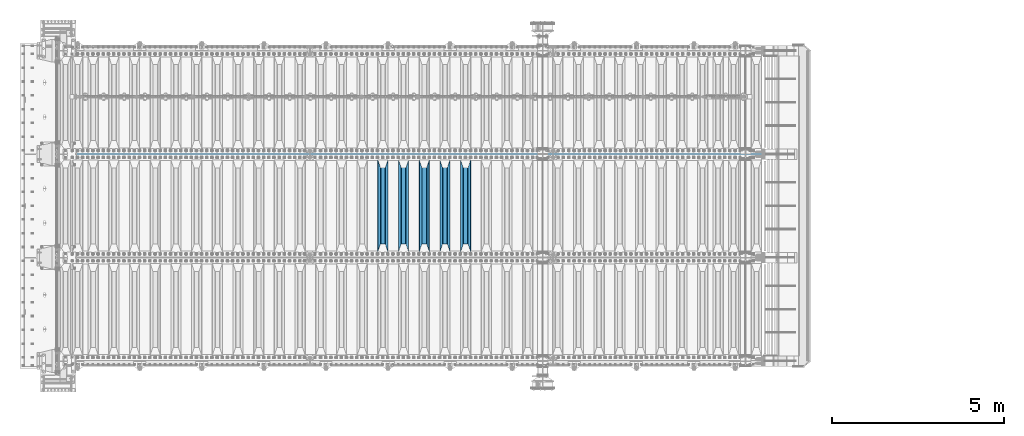
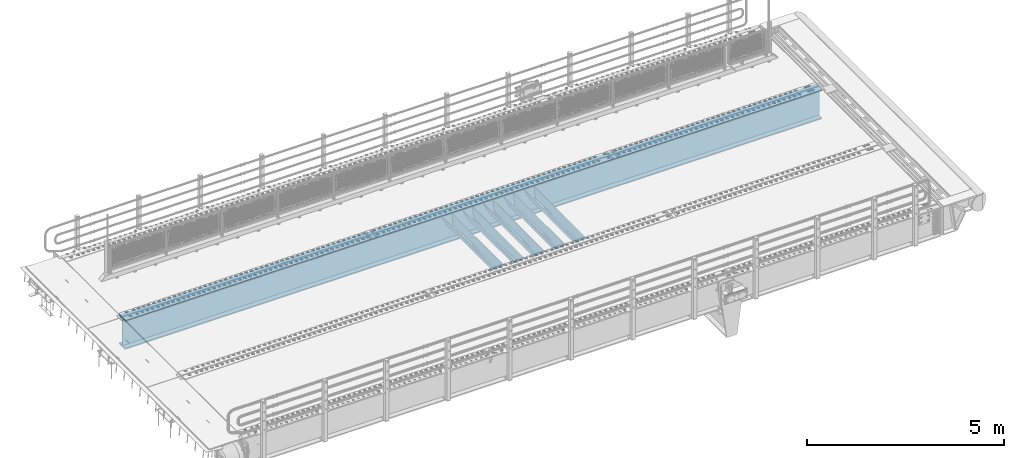
# One storey, part 125 of 270: 6 beams.
"""IFC2X3 building model written with IfcOpenShell, lengths in millimetres."""

from ifc_helpers import new_model, si_unit, frame, origin_with_axes, place, context, subcontext, project, spatial, faceted_brep, material, type_object, element, save


model = new_model("IFC2X3")

# Units and contexts
model_context = context("Model", 3, precision=1e-05, world=origin_with_axes())
body_context = subcontext(model_context, "Body", "Model", "MODEL_VIEW")
ifc_project = project(units=[si_unit("LENGTHUNIT", "METRE", prefix="MILLI"), si_unit("AREAUNIT", "SQUARE_METRE"), si_unit("VOLUMEUNIT", "CUBIC_METRE"), si_unit("MASSUNIT", "GRAM", prefix="KILO"), si_unit("TIMEUNIT", "SECOND"), si_unit("PLANEANGLEUNIT", "RADIAN"), si_unit("SOLIDANGLEUNIT", "STERADIAN"), si_unit("THERMODYNAMICTEMPERATUREUNIT", "DEGREE_CELSIUS"), si_unit("LUMINOUSINTENSITYUNIT", "LUMEN")], contexts=[model_context])

# Site, building, storey
site_placement = place(None, origin_with_axes())
site = spatial("IfcSite", under=ifc_project, at=site_placement, CompositionType="ELEMENT")
building_placement = place(site_placement, origin_with_axes())
building = spatial("IfcBuilding", under=site, at=building_placement, Name="Standard", CompositionType="ELEMENT")
storey_placement = place(building_placement, origin_with_axes())
storey = spatial("IfcBuildingStorey", under=building, at=storey_placement, Name="Undefined", CompositionType="ELEMENT", Elevation=0.0)

# Beams
ifc_material = material(Name="STEEL/S355N")
beam_type_1 = type_object("IfcBeamType", PredefinedType="NOTDEFINED")
beam_1_placement = place(storey_placement, frame((11800.0, -20825.0, -115.0), z_axis=(0.0, 0.0, 1.0), x_axis=(0.0, 1.0, 0.0)))
element("IfcBeam", 1, at=beam_1_placement, inside=storey, type_object=beam_type_1, material=ifc_material, context=body_context, shape_type="Brep", body=[
    faceted_brep([(0.0, 150.0, 115.0), (0.0, 143.689999999999, 115.0), (2650.00000000297, 143.689999999999, 115.0), (2650.00000000297, 150.0, 115.0), (2650.00000000297, 142.059565218398, 110.000000003096), (2650.00000000297, 148.3695652184, 110.000000003096), (2441.90079219209, -80.1103600731112, -98.0992078077845), (2437.7588105432, -77.5672621345584, -102.241189456673), (2434.06523489747, -74.4080125315522, -105.934765102404), (2430.9108609509, -70.710272125576, -109.089139048974), (2428.37322971128, -66.5649389910068, -111.626770288588), (2426.51472138055, -62.0739139532889, -113.485278619323), (2425.38102192092, -57.3475956567672, -114.618978078955), (2424.99999999987, -52.5021667386536, -115.0), (2424.99999999987, 52.5021667386536, -115.0), (2425.38102192092, 57.3475956567672, -114.618978078955), (2426.51472138055, 62.0739139532889, -113.485278619323), (2428.37322971128, 66.5649389910068, -111.626770288588), (2430.9108609509, 70.710272125576, -109.089139048974), (2434.06523489747, 74.4080125315522, -105.934765102404), (2437.7588105432, 77.5672621345584, -102.241189456673), (2441.90079219209, 80.1103600731112, -98.0992078077846), (2446.38936140511, 81.9747917625791, -93.6106385947584), (2448.2494850041, 76.2713538057251, -91.7505149957729), (2444.62967112263, 74.76777986261, -95.3703288772456), (2441.28936334126, 72.7168944282894, -98.710636658607), (2438.31067330439, 70.1691124903846, -101.689326695487), (2435.76682334747, 67.1870637758839, -104.233176652398), (2433.72034654133, 63.8440531834895, -106.279653458539), (2432.22154950042, 60.222258798236, -107.778450499454), (2431.30727574265, 56.4107117849089, -108.692724257221), (2430.99999999987, 52.5031078186876, -109.0), (2430.99999999987, -52.5031078186876, -109.0), (2431.30727574265, -56.4107117849089, -108.692724257221), (2432.22154950042, -60.222258798236, -107.778450499454), (2433.72034654133, -63.8440531834895, -106.279653458539), (2435.76682334747, -67.1870637758839, -104.233176652398), (2438.31067330438, -70.1691124903846, -101.689326695487), (2441.28936334126, -72.7168944282894, -98.7106366586071), (2444.62967112263, -74.76777986261, -95.3703288772457), (2448.2494850041, -76.2713538057251, -91.7505149957729), (2650.00000000297, -142.059565218398, 110.000000003096), (2650.00000000297, -148.3695652184, 110.000000003096), (2446.38936140511, -81.9747917625791, -93.6106385947584), (2650.00000000297, -143.689999999999, 115.0), (2650.00000000297, -150.0, 115.0), (0.0, -143.689999999999, 115.0), (0.0, -150.0, 115.0), (0.0, -148.369565218261, 110.000000002672), (203.610638597431, -81.9747917625791, -93.6106385947584), (208.099207810457, -80.1103600731112, -98.0992078077845), (212.241189459342, -77.5672621345584, -102.241189456673), (215.934765105078, -74.4080125315522, -105.934765102404), (219.089139051644, -70.710272125576, -109.089139048974), (221.626770291259, -66.5649389910068, -111.626770288588), (223.485278621993, -62.0739139532889, -113.485278619323), (224.618978081628, -57.3475956567672, -114.618978078955), (225.00000000267, -52.5021667386536, -115.0), (225.00000000267, 52.5021667386536, -115.0), (224.618978081628, 57.3475956567672, -114.618978078955), (223.485278621993, 62.0739139532889, -113.485278619323), (221.626770291259, 66.5649389910068, -111.626770288588), (219.089139051644, 70.710272125576, -109.089139048974), (215.934765105078, 74.4080125315522, -105.934765102404), (212.241189459342, 77.5672621345584, -102.241189456673), (208.099207810457, 80.1103600731112, -98.0992078077846), (203.610638597431, 81.9747917625791, -93.6106385947584), (0.0, 148.369565218261, 110.000000002672), (0.0, 142.05956521826, 110.000000002672), (201.750514998446, 76.2713538057251, -91.7505149957729), (205.370328879915, 74.76777986261, -95.3703288772456), (208.710636661279, 72.7168944282894, -98.710636658607), (211.689326698157, 70.1691124903846, -101.689326695487), (214.233176655071, 67.1870637758839, -104.233176652398), (216.27965346121, 63.8440531834895, -106.279653458539), (217.778450502126, 60.222258798236, -107.778450499454), (218.692724259894, 56.4107117849089, -108.692724257221), (219.00000000267, 52.5031078186876, -109.0), (219.00000000267, -52.5031078186876, -109.0), (218.692724259894, -56.4107117849089, -108.692724257221), (217.778450502123, -60.222258798236, -107.778450499454), (216.27965346121, -63.8440531834895, -106.279653458539), (214.233176655071, -67.1870637758839, -104.233176652398), (211.689326698157, -70.1691124903846, -101.689326695487), (208.710636661279, -72.7168944282894, -98.7106366586071), (205.370328879915, -74.76777986261, -95.3703288772457), (201.750514998446, -76.2713538057251, -91.7505149957729), (0.0, -142.05956521826, 110.000000002672)], [[[0, 1, 2, 3]], [[3, 2, 4, 5]], [[6, 7, 8, 9, 10, 11, 12, 13, 14, 15, 16, 17, 18, 19, 20, 21, 22, 5, 4, 23, 24, 25, 26, 27, 28, 29, 30, 31, 32, 33, 34, 35, 36, 37, 38, 39, 40, 41, 42, 43]], [[44, 45, 42, 41]], [[46, 47, 45, 44]], [[43, 42, 45, 47, 48, 49]], [[6, 43, 49, 50]], [[7, 6, 50, 51]], [[8, 7, 51, 52]], [[9, 8, 52, 53]], [[10, 9, 53, 54]], [[11, 10, 54, 55]], [[12, 11, 55, 56]], [[13, 12, 56, 57]], [[14, 13, 57, 58]], [[15, 14, 58, 59]], [[16, 15, 59, 60]], [[17, 16, 60, 61]], [[18, 17, 61, 62]], [[19, 18, 62, 63]], [[20, 19, 63, 64]], [[21, 20, 64, 65]], [[22, 21, 65, 66]], [[0, 3, 5, 22, 66, 67]], [[1, 0, 67, 68]], [[23, 4, 2, 1, 68, 69]], [[24, 23, 69, 70]], [[25, 24, 70, 71]], [[26, 25, 71, 72]], [[27, 26, 72, 73]], [[28, 27, 73, 74]], [[29, 28, 74, 75]], [[30, 29, 75, 76]], [[31, 30, 76, 77]], [[32, 31, 77, 78]], [[33, 32, 78, 79]], [[34, 33, 79, 80]], [[35, 34, 80, 81]], [[36, 35, 81, 82]], [[37, 36, 82, 83]], [[38, 37, 83, 84]], [[39, 38, 84, 85]], [[40, 39, 85, 86]], [[46, 44, 41, 40, 86, 87]], [[47, 46, 87, 48]], [[86, 85, 84, 83, 82, 81, 80, 79, 78, 77, 76, 75, 74, 73, 72, 71, 70, 69, 68, 67, 66, 65, 64, 63, 62, 61, 60, 59, 58, 57, 56, 55, 54, 53, 52, 51, 50, 49, 48, 87]]]),
])
beam_2_placement = place(storey_placement, frame((11200.0, -20825.0, -115.0), z_axis=(0.0, 0.0, 1.0), x_axis=(0.0, 1.0, 0.0)))
element("IfcBeam", 2, at=beam_2_placement, inside=storey, type_object=beam_type_1, material=ifc_material, context=body_context, shape_type="Brep", body=[
    faceted_brep([(0.0, 150.0, 115.0), (0.0, 143.689999999999, 115.0), (2650.00000000297, 143.689999999999, 115.0), (2650.00000000297, 150.0, 115.0), (2650.00000000297, 142.059565218398, 110.000000003096), (2650.00000000297, 148.3695652184, 110.000000003096), (2441.90079219209, -80.1103600731112, -98.0992078077845), (2437.7588105432, -77.5672621345584, -102.241189456673), (2434.06523489747, -74.4080125315522, -105.934765102404), (2430.9108609509, -70.710272125576, -109.089139048974), (2428.37322971128, -66.5649389910068, -111.626770288588), (2426.51472138055, -62.0739139532889, -113.485278619323), (2425.38102192092, -57.3475956567672, -114.618978078955), (2424.99999999987, -52.5021667386536, -115.0), (2424.99999999987, 52.5021667386536, -115.0), (2425.38102192092, 57.3475956567672, -114.618978078955), (2426.51472138055, 62.0739139532889, -113.485278619323), (2428.37322971128, 66.5649389910068, -111.626770288588), (2430.9108609509, 70.710272125576, -109.089139048974), (2434.06523489747, 74.4080125315522, -105.934765102404), (2437.7588105432, 77.5672621345584, -102.241189456673), (2441.90079219209, 80.1103600731112, -98.0992078077846), (2446.38936140511, 81.9747917625791, -93.6106385947584), (2448.2494850041, 76.2713538057251, -91.7505149957729), (2444.62967112263, 74.76777986261, -95.3703288772456), (2441.28936334126, 72.7168944282894, -98.710636658607), (2438.31067330439, 70.1691124903846, -101.689326695487), (2435.76682334747, 67.1870637758839, -104.233176652398), (2433.72034654133, 63.8440531834895, -106.279653458539), (2432.22154950042, 60.222258798236, -107.778450499454), (2431.30727574265, 56.4107117849089, -108.692724257221), (2430.99999999987, 52.5031078186876, -109.0), (2430.99999999987, -52.5031078186876, -109.0), (2431.30727574265, -56.4107117849089, -108.692724257221), (2432.22154950042, -60.222258798236, -107.778450499454), (2433.72034654133, -63.8440531834895, -106.279653458539), (2435.76682334747, -67.1870637758839, -104.233176652398), (2438.31067330438, -70.1691124903846, -101.689326695487), (2441.28936334126, -72.7168944282894, -98.7106366586071), (2444.62967112263, -74.76777986261, -95.3703288772457), (2448.2494850041, -76.2713538057251, -91.7505149957729), (2650.00000000297, -142.059565218398, 110.000000003096), (2650.00000000297, -148.3695652184, 110.000000003096), (2446.38936140511, -81.9747917625791, -93.6106385947584), (2650.00000000297, -143.689999999999, 115.0), (2650.00000000297, -150.0, 115.0), (0.0, -143.689999999999, 115.0), (0.0, -150.0, 115.0), (0.0, -148.369565218261, 110.000000002672), (203.610638597431, -81.9747917625791, -93.6106385947584), (208.099207810457, -80.1103600731112, -98.0992078077845), (212.241189459342, -77.5672621345584, -102.241189456673), (215.934765105078, -74.4080125315522, -105.934765102404), (219.089139051644, -70.710272125576, -109.089139048974), (221.626770291259, -66.5649389910068, -111.626770288588), (223.485278621993, -62.0739139532889, -113.485278619323), (224.618978081628, -57.3475956567672, -114.618978078955), (225.00000000267, -52.5021667386536, -115.0), (225.00000000267, 52.5021667386536, -115.0), (224.618978081628, 57.3475956567672, -114.618978078955), (223.485278621993, 62.0739139532889, -113.485278619323), (221.626770291259, 66.5649389910068, -111.626770288588), (219.089139051644, 70.710272125576, -109.089139048974), (215.934765105078, 74.4080125315522, -105.934765102404), (212.241189459342, 77.5672621345584, -102.241189456673), (208.099207810457, 80.1103600731112, -98.0992078077846), (203.610638597431, 81.9747917625791, -93.6106385947584), (0.0, 148.369565218261, 110.000000002672), (0.0, 142.05956521826, 110.000000002672), (201.750514998446, 76.2713538057251, -91.7505149957729), (205.370328879915, 74.76777986261, -95.3703288772456), (208.710636661279, 72.7168944282894, -98.710636658607), (211.689326698157, 70.1691124903846, -101.689326695487), (214.233176655071, 67.1870637758839, -104.233176652398), (216.27965346121, 63.8440531834895, -106.279653458539), (217.778450502126, 60.222258798236, -107.778450499454), (218.692724259894, 56.4107117849089, -108.692724257221), (219.00000000267, 52.5031078186876, -109.0), (219.00000000267, -52.5031078186876, -109.0), (218.692724259894, -56.4107117849089, -108.692724257221), (217.778450502123, -60.222258798236, -107.778450499454), (216.27965346121, -63.8440531834895, -106.279653458539), (214.233176655071, -67.1870637758839, -104.233176652398), (211.689326698157, -70.1691124903846, -101.689326695487), (208.710636661279, -72.7168944282894, -98.7106366586071), (205.370328879915, -74.76777986261, -95.3703288772457), (201.750514998446, -76.2713538057251, -91.7505149957729), (0.0, -142.05956521826, 110.000000002672)], [[[0, 1, 2, 3]], [[3, 2, 4, 5]], [[6, 7, 8, 9, 10, 11, 12, 13, 14, 15, 16, 17, 18, 19, 20, 21, 22, 5, 4, 23, 24, 25, 26, 27, 28, 29, 30, 31, 32, 33, 34, 35, 36, 37, 38, 39, 40, 41, 42, 43]], [[44, 45, 42, 41]], [[46, 47, 45, 44]], [[43, 42, 45, 47, 48, 49]], [[6, 43, 49, 50]], [[7, 6, 50, 51]], [[8, 7, 51, 52]], [[9, 8, 52, 53]], [[10, 9, 53, 54]], [[11, 10, 54, 55]], [[12, 11, 55, 56]], [[13, 12, 56, 57]], [[14, 13, 57, 58]], [[15, 14, 58, 59]], [[16, 15, 59, 60]], [[17, 16, 60, 61]], [[18, 17, 61, 62]], [[19, 18, 62, 63]], [[20, 19, 63, 64]], [[21, 20, 64, 65]], [[22, 21, 65, 66]], [[0, 3, 5, 22, 66, 67]], [[1, 0, 67, 68]], [[23, 4, 2, 1, 68, 69]], [[24, 23, 69, 70]], [[25, 24, 70, 71]], [[26, 25, 71, 72]], [[27, 26, 72, 73]], [[28, 27, 73, 74]], [[29, 28, 74, 75]], [[30, 29, 75, 76]], [[31, 30, 76, 77]], [[32, 31, 77, 78]], [[33, 32, 78, 79]], [[34, 33, 79, 80]], [[35, 34, 80, 81]], [[36, 35, 81, 82]], [[37, 36, 82, 83]], [[38, 37, 83, 84]], [[39, 38, 84, 85]], [[40, 39, 85, 86]], [[46, 44, 41, 40, 86, 87]], [[47, 46, 87, 48]], [[86, 85, 84, 83, 82, 81, 80, 79, 78, 77, 76, 75, 74, 73, 72, 71, 70, 69, 68, 67, 66, 65, 64, 63, 62, 61, 60, 59, 58, 57, 56, 55, 54, 53, 52, 51, 50, 49, 48, 87]]]),
])
beam_3_placement = place(storey_placement, frame((10600.0, -20825.0, -115.0), z_axis=(0.0, 0.0, 1.0), x_axis=(0.0, 1.0, 0.0)))
element("IfcBeam", 3, at=beam_3_placement, inside=storey, type_object=beam_type_1, material=ifc_material, context=body_context, shape_type="Brep", body=[
    faceted_brep([(0.0, 150.0, 115.0), (0.0, 143.689999999999, 115.0), (2650.00000000297, 143.689999999999, 115.0), (2650.00000000297, 150.0, 115.0), (2650.00000000297, 142.059565218398, 110.000000003096), (2650.00000000297, 148.3695652184, 110.000000003096), (2441.90079219209, -80.1103600731112, -98.0992078077845), (2437.7588105432, -77.5672621345584, -102.241189456673), (2434.06523489747, -74.4080125315522, -105.934765102404), (2430.9108609509, -70.710272125576, -109.089139048974), (2428.37322971128, -66.5649389910068, -111.626770288588), (2426.51472138055, -62.0739139532889, -113.485278619323), (2425.38102192092, -57.3475956567672, -114.618978078955), (2424.99999999987, -52.5021667386536, -115.0), (2424.99999999987, 52.5021667386536, -115.0), (2425.38102192092, 57.3475956567672, -114.618978078955), (2426.51472138055, 62.0739139532889, -113.485278619323), (2428.37322971128, 66.5649389910068, -111.626770288588), (2430.9108609509, 70.710272125576, -109.089139048974), (2434.06523489747, 74.4080125315522, -105.934765102404), (2437.7588105432, 77.5672621345584, -102.241189456673), (2441.90079219209, 80.1103600731112, -98.0992078077846), (2446.38936140511, 81.9747917625791, -93.6106385947584), (2448.2494850041, 76.2713538057251, -91.7505149957729), (2444.62967112263, 74.76777986261, -95.3703288772456), (2441.28936334126, 72.7168944282894, -98.710636658607), (2438.31067330439, 70.1691124903846, -101.689326695487), (2435.76682334747, 67.1870637758839, -104.233176652398), (2433.72034654133, 63.8440531834895, -106.279653458539), (2432.22154950042, 60.222258798236, -107.778450499454), (2431.30727574265, 56.4107117849089, -108.692724257221), (2430.99999999987, 52.5031078186876, -109.0), (2430.99999999987, -52.5031078186876, -109.0), (2431.30727574265, -56.4107117849089, -108.692724257221), (2432.22154950042, -60.222258798236, -107.778450499454), (2433.72034654133, -63.8440531834895, -106.279653458539), (2435.76682334747, -67.1870637758839, -104.233176652398), (2438.31067330438, -70.1691124903846, -101.689326695487), (2441.28936334126, -72.7168944282894, -98.7106366586071), (2444.62967112263, -74.76777986261, -95.3703288772457), (2448.2494850041, -76.2713538057251, -91.7505149957729), (2650.00000000297, -142.059565218398, 110.000000003096), (2650.00000000297, -148.3695652184, 110.000000003096), (2446.38936140511, -81.9747917625791, -93.6106385947584), (2650.00000000297, -143.689999999999, 115.0), (2650.00000000297, -150.0, 115.0), (0.0, -143.689999999999, 115.0), (0.0, -150.0, 115.0), (0.0, -148.369565218261, 110.000000002672), (203.610638597431, -81.9747917625791, -93.6106385947584), (208.099207810457, -80.1103600731112, -98.0992078077845), (212.241189459342, -77.5672621345584, -102.241189456673), (215.934765105078, -74.4080125315522, -105.934765102404), (219.089139051644, -70.710272125576, -109.089139048974), (221.626770291259, -66.5649389910068, -111.626770288588), (223.485278621993, -62.0739139532889, -113.485278619323), (224.618978081628, -57.3475956567672, -114.618978078955), (225.00000000267, -52.5021667386536, -115.0), (225.00000000267, 52.5021667386536, -115.0), (224.618978081628, 57.3475956567672, -114.618978078955), (223.485278621993, 62.0739139532889, -113.485278619323), (221.626770291259, 66.5649389910068, -111.626770288588), (219.089139051644, 70.710272125576, -109.089139048974), (215.934765105078, 74.4080125315522, -105.934765102404), (212.241189459342, 77.5672621345584, -102.241189456673), (208.099207810457, 80.1103600731112, -98.0992078077846), (203.610638597431, 81.9747917625791, -93.6106385947584), (0.0, 148.369565218261, 110.000000002672), (0.0, 142.05956521826, 110.000000002672), (201.750514998446, 76.2713538057251, -91.7505149957729), (205.370328879915, 74.76777986261, -95.3703288772456), (208.710636661279, 72.7168944282894, -98.710636658607), (211.689326698157, 70.1691124903846, -101.689326695487), (214.233176655071, 67.1870637758839, -104.233176652398), (216.27965346121, 63.8440531834895, -106.279653458539), (217.778450502126, 60.222258798236, -107.778450499454), (218.692724259894, 56.4107117849089, -108.692724257221), (219.00000000267, 52.5031078186876, -109.0), (219.00000000267, -52.5031078186876, -109.0), (218.692724259894, -56.4107117849089, -108.692724257221), (217.778450502123, -60.222258798236, -107.778450499454), (216.27965346121, -63.8440531834895, -106.279653458539), (214.233176655071, -67.1870637758839, -104.233176652398), (211.689326698157, -70.1691124903846, -101.689326695487), (208.710636661279, -72.7168944282894, -98.7106366586071), (205.370328879915, -74.76777986261, -95.3703288772457), (201.750514998446, -76.2713538057251, -91.7505149957729), (0.0, -142.05956521826, 110.000000002672)], [[[0, 1, 2, 3]], [[3, 2, 4, 5]], [[6, 7, 8, 9, 10, 11, 12, 13, 14, 15, 16, 17, 18, 19, 20, 21, 22, 5, 4, 23, 24, 25, 26, 27, 28, 29, 30, 31, 32, 33, 34, 35, 36, 37, 38, 39, 40, 41, 42, 43]], [[44, 45, 42, 41]], [[46, 47, 45, 44]], [[43, 42, 45, 47, 48, 49]], [[6, 43, 49, 50]], [[7, 6, 50, 51]], [[8, 7, 51, 52]], [[9, 8, 52, 53]], [[10, 9, 53, 54]], [[11, 10, 54, 55]], [[12, 11, 55, 56]], [[13, 12, 56, 57]], [[14, 13, 57, 58]], [[15, 14, 58, 59]], [[16, 15, 59, 60]], [[17, 16, 60, 61]], [[18, 17, 61, 62]], [[19, 18, 62, 63]], [[20, 19, 63, 64]], [[21, 20, 64, 65]], [[22, 21, 65, 66]], [[0, 3, 5, 22, 66, 67]], [[1, 0, 67, 68]], [[23, 4, 2, 1, 68, 69]], [[24, 23, 69, 70]], [[25, 24, 70, 71]], [[26, 25, 71, 72]], [[27, 26, 72, 73]], [[28, 27, 73, 74]], [[29, 28, 74, 75]], [[30, 29, 75, 76]], [[31, 30, 76, 77]], [[32, 31, 77, 78]], [[33, 32, 78, 79]], [[34, 33, 79, 80]], [[35, 34, 80, 81]], [[36, 35, 81, 82]], [[37, 36, 82, 83]], [[38, 37, 83, 84]], [[39, 38, 84, 85]], [[40, 39, 85, 86]], [[46, 44, 41, 40, 86, 87]], [[47, 46, 87, 48]], [[86, 85, 84, 83, 82, 81, 80, 79, 78, 77, 76, 75, 74, 73, 72, 71, 70, 69, 68, 67, 66, 65, 64, 63, 62, 61, 60, 59, 58, 57, 56, 55, 54, 53, 52, 51, 50, 49, 48, 87]]]),
])
beam_4_placement = place(storey_placement, frame((10000.0, -20825.0, -115.0), z_axis=(0.0, 0.0, 1.0), x_axis=(0.0, 1.0, 0.0)))
element("IfcBeam", 4, at=beam_4_placement, inside=storey, type_object=beam_type_1, material=ifc_material, context=body_context, shape_type="Brep", body=[
    faceted_brep([(0.0, 150.0, 115.0), (0.0, 143.689999999999, 115.0), (2650.00000000297, 143.689999999999, 115.0), (2650.00000000297, 150.0, 115.0), (2650.00000000297, 142.059565218398, 110.000000003096), (2650.00000000297, 148.3695652184, 110.000000003096), (2441.90079219209, -80.1103600731112, -98.0992078077845), (2437.7588105432, -77.5672621345584, -102.241189456673), (2434.06523489747, -74.4080125315522, -105.934765102404), (2430.9108609509, -70.710272125576, -109.089139048974), (2428.37322971128, -66.5649389910068, -111.626770288588), (2426.51472138055, -62.0739139532889, -113.485278619323), (2425.38102192092, -57.3475956567672, -114.618978078955), (2424.99999999987, -52.5021667386536, -115.0), (2424.99999999987, 52.5021667386536, -115.0), (2425.38102192092, 57.3475956567672, -114.618978078955), (2426.51472138055, 62.0739139532889, -113.485278619323), (2428.37322971128, 66.5649389910068, -111.626770288588), (2430.9108609509, 70.710272125576, -109.089139048974), (2434.06523489747, 74.4080125315522, -105.934765102404), (2437.7588105432, 77.5672621345584, -102.241189456673), (2441.90079219209, 80.1103600731112, -98.0992078077846), (2446.38936140511, 81.9747917625791, -93.6106385947584), (2448.2494850041, 76.2713538057251, -91.7505149957729), (2444.62967112263, 74.76777986261, -95.3703288772456), (2441.28936334126, 72.7168944282894, -98.710636658607), (2438.31067330439, 70.1691124903846, -101.689326695487), (2435.76682334747, 67.1870637758839, -104.233176652398), (2433.72034654133, 63.8440531834895, -106.279653458539), (2432.22154950042, 60.222258798236, -107.778450499454), (2431.30727574265, 56.4107117849089, -108.692724257221), (2430.99999999987, 52.5031078186876, -109.0), (2430.99999999987, -52.5031078186876, -109.0), (2431.30727574265, -56.4107117849089, -108.692724257221), (2432.22154950042, -60.222258798236, -107.778450499454), (2433.72034654133, -63.8440531834895, -106.279653458539), (2435.76682334747, -67.1870637758839, -104.233176652398), (2438.31067330438, -70.1691124903846, -101.689326695487), (2441.28936334126, -72.7168944282894, -98.7106366586071), (2444.62967112263, -74.76777986261, -95.3703288772457), (2448.2494850041, -76.2713538057251, -91.7505149957729), (2650.00000000297, -142.059565218398, 110.000000003096), (2650.00000000297, -148.3695652184, 110.000000003096), (2446.38936140511, -81.9747917625791, -93.6106385947584), (2650.00000000297, -143.689999999999, 115.0), (2650.00000000297, -150.0, 115.0), (0.0, -143.689999999999, 115.0), (0.0, -150.0, 115.0), (0.0, -148.369565218261, 110.000000002672), (203.610638597431, -81.9747917625791, -93.6106385947584), (208.099207810457, -80.1103600731112, -98.0992078077845), (212.241189459342, -77.5672621345584, -102.241189456673), (215.934765105078, -74.4080125315522, -105.934765102404), (219.089139051644, -70.710272125576, -109.089139048974), (221.626770291259, -66.5649389910068, -111.626770288588), (223.485278621993, -62.0739139532889, -113.485278619323), (224.618978081628, -57.3475956567672, -114.618978078955), (225.00000000267, -52.5021667386536, -115.0), (225.00000000267, 52.5021667386536, -115.0), (224.618978081628, 57.3475956567672, -114.618978078955), (223.485278621993, 62.0739139532889, -113.485278619323), (221.626770291259, 66.5649389910068, -111.626770288588), (219.089139051644, 70.710272125576, -109.089139048974), (215.934765105078, 74.4080125315522, -105.934765102404), (212.241189459342, 77.5672621345584, -102.241189456673), (208.099207810457, 80.1103600731112, -98.0992078077846), (203.610638597431, 81.9747917625791, -93.6106385947584), (0.0, 148.369565218261, 110.000000002672), (0.0, 142.05956521826, 110.000000002672), (201.750514998446, 76.2713538057251, -91.7505149957729), (205.370328879915, 74.76777986261, -95.3703288772456), (208.710636661279, 72.7168944282894, -98.710636658607), (211.689326698157, 70.1691124903846, -101.689326695487), (214.233176655071, 67.1870637758839, -104.233176652398), (216.27965346121, 63.8440531834895, -106.279653458539), (217.778450502126, 60.222258798236, -107.778450499454), (218.692724259894, 56.4107117849089, -108.692724257221), (219.00000000267, 52.5031078186876, -109.0), (219.00000000267, -52.5031078186876, -109.0), (218.692724259894, -56.4107117849089, -108.692724257221), (217.778450502123, -60.222258798236, -107.778450499454), (216.27965346121, -63.8440531834895, -106.279653458539), (214.233176655071, -67.1870637758839, -104.233176652398), (211.689326698157, -70.1691124903846, -101.689326695487), (208.710636661279, -72.7168944282894, -98.7106366586071), (205.370328879915, -74.76777986261, -95.3703288772457), (201.750514998446, -76.2713538057251, -91.7505149957729), (0.0, -142.05956521826, 110.000000002672)], [[[0, 1, 2, 3]], [[3, 2, 4, 5]], [[6, 7, 8, 9, 10, 11, 12, 13, 14, 15, 16, 17, 18, 19, 20, 21, 22, 5, 4, 23, 24, 25, 26, 27, 28, 29, 30, 31, 32, 33, 34, 35, 36, 37, 38, 39, 40, 41, 42, 43]], [[44, 45, 42, 41]], [[46, 47, 45, 44]], [[43, 42, 45, 47, 48, 49]], [[6, 43, 49, 50]], [[7, 6, 50, 51]], [[8, 7, 51, 52]], [[9, 8, 52, 53]], [[10, 9, 53, 54]], [[11, 10, 54, 55]], [[12, 11, 55, 56]], [[13, 12, 56, 57]], [[14, 13, 57, 58]], [[15, 14, 58, 59]], [[16, 15, 59, 60]], [[17, 16, 60, 61]], [[18, 17, 61, 62]], [[19, 18, 62, 63]], [[20, 19, 63, 64]], [[21, 20, 64, 65]], [[22, 21, 65, 66]], [[0, 3, 5, 22, 66, 67]], [[1, 0, 67, 68]], [[23, 4, 2, 1, 68, 69]], [[24, 23, 69, 70]], [[25, 24, 70, 71]], [[26, 25, 71, 72]], [[27, 26, 72, 73]], [[28, 27, 73, 74]], [[29, 28, 74, 75]], [[30, 29, 75, 76]], [[31, 30, 76, 77]], [[32, 31, 77, 78]], [[33, 32, 78, 79]], [[34, 33, 79, 80]], [[35, 34, 80, 81]], [[36, 35, 81, 82]], [[37, 36, 82, 83]], [[38, 37, 83, 84]], [[39, 38, 84, 85]], [[40, 39, 85, 86]], [[46, 44, 41, 40, 86, 87]], [[47, 46, 87, 48]], [[86, 85, 84, 83, 82, 81, 80, 79, 78, 77, 76, 75, 74, 73, 72, 71, 70, 69, 68, 67, 66, 65, 64, 63, 62, 61, 60, 59, 58, 57, 56, 55, 54, 53, 52, 51, 50, 49, 48, 87]]]),
])
beam_5_placement = place(storey_placement, frame((9400.0, -20825.0, -115.0), z_axis=(0.0, 0.0, 1.0), x_axis=(0.0, 1.0, 0.0)))
element("IfcBeam", 5, at=beam_5_placement, inside=storey, type_object=beam_type_1, material=ifc_material, context=body_context, shape_type="Brep", body=[
    faceted_brep([(0.0, 150.0, 115.0), (0.0, 143.689999999999, 115.0), (2650.00000000297, 143.689999999999, 115.0), (2650.00000000297, 150.0, 115.0), (2650.00000000297, 142.059565218398, 110.000000003096), (2650.00000000297, 148.3695652184, 110.000000003096), (2441.90079219209, -80.1103600731112, -98.0992078077845), (2437.7588105432, -77.5672621345584, -102.241189456673), (2434.06523489747, -74.4080125315522, -105.934765102404), (2430.9108609509, -70.710272125576, -109.089139048974), (2428.37322971128, -66.5649389910068, -111.626770288588), (2426.51472138055, -62.0739139532889, -113.485278619323), (2425.38102192092, -57.3475956567672, -114.618978078955), (2424.99999999987, -52.5021667386536, -115.0), (2424.99999999987, 52.5021667386536, -115.0), (2425.38102192092, 57.3475956567672, -114.618978078955), (2426.51472138055, 62.0739139532889, -113.485278619323), (2428.37322971128, 66.5649389910068, -111.626770288588), (2430.9108609509, 70.710272125576, -109.089139048974), (2434.06523489747, 74.4080125315522, -105.934765102404), (2437.7588105432, 77.5672621345584, -102.241189456673), (2441.90079219209, 80.1103600731112, -98.0992078077846), (2446.38936140511, 81.9747917625791, -93.6106385947584), (2448.2494850041, 76.2713538057251, -91.7505149957729), (2444.62967112263, 74.76777986261, -95.3703288772456), (2441.28936334126, 72.7168944282894, -98.710636658607), (2438.31067330439, 70.1691124903846, -101.689326695487), (2435.76682334747, 67.1870637758839, -104.233176652398), (2433.72034654133, 63.8440531834895, -106.279653458539), (2432.22154950042, 60.222258798236, -107.778450499454), (2431.30727574265, 56.4107117849089, -108.692724257221), (2430.99999999987, 52.5031078186876, -109.0), (2430.99999999987, -52.5031078186876, -109.0), (2431.30727574265, -56.4107117849089, -108.692724257221), (2432.22154950042, -60.222258798236, -107.778450499454), (2433.72034654133, -63.8440531834895, -106.279653458539), (2435.76682334747, -67.1870637758839, -104.233176652398), (2438.31067330438, -70.1691124903846, -101.689326695487), (2441.28936334126, -72.7168944282894, -98.7106366586071), (2444.62967112263, -74.76777986261, -95.3703288772457), (2448.2494850041, -76.2713538057251, -91.7505149957729), (2650.00000000297, -142.059565218398, 110.000000003096), (2650.00000000297, -148.3695652184, 110.000000003096), (2446.38936140511, -81.9747917625791, -93.6106385947584), (2650.00000000297, -143.689999999999, 115.0), (2650.00000000297, -150.0, 115.0), (0.0, -143.689999999999, 115.0), (0.0, -150.0, 115.0), (0.0, -148.369565218261, 110.000000002672), (203.610638597431, -81.9747917625791, -93.6106385947584), (208.099207810457, -80.1103600731112, -98.0992078077845), (212.241189459342, -77.5672621345584, -102.241189456673), (215.934765105078, -74.4080125315522, -105.934765102404), (219.089139051644, -70.710272125576, -109.089139048974), (221.626770291259, -66.5649389910068, -111.626770288588), (223.485278621993, -62.0739139532889, -113.485278619323), (224.618978081628, -57.3475956567672, -114.618978078955), (225.00000000267, -52.5021667386536, -115.0), (225.00000000267, 52.5021667386536, -115.0), (224.618978081628, 57.3475956567672, -114.618978078955), (223.485278621993, 62.0739139532889, -113.485278619323), (221.626770291259, 66.5649389910068, -111.626770288588), (219.089139051644, 70.710272125576, -109.089139048974), (215.934765105078, 74.4080125315522, -105.934765102404), (212.241189459342, 77.5672621345584, -102.241189456673), (208.099207810457, 80.1103600731112, -98.0992078077846), (203.610638597431, 81.9747917625791, -93.6106385947584), (0.0, 148.369565218261, 110.000000002672), (0.0, 142.05956521826, 110.000000002672), (201.750514998446, 76.2713538057251, -91.7505149957729), (205.370328879915, 74.76777986261, -95.3703288772456), (208.710636661279, 72.7168944282894, -98.710636658607), (211.689326698157, 70.1691124903846, -101.689326695487), (214.233176655071, 67.1870637758839, -104.233176652398), (216.27965346121, 63.8440531834895, -106.279653458539), (217.778450502126, 60.222258798236, -107.778450499454), (218.692724259894, 56.4107117849089, -108.692724257221), (219.00000000267, 52.5031078186876, -109.0), (219.00000000267, -52.5031078186876, -109.0), (218.692724259894, -56.4107117849089, -108.692724257221), (217.778450502123, -60.222258798236, -107.778450499454), (216.27965346121, -63.8440531834895, -106.279653458539), (214.233176655071, -67.1870637758839, -104.233176652398), (211.689326698157, -70.1691124903846, -101.689326695487), (208.710636661279, -72.7168944282894, -98.7106366586071), (205.370328879915, -74.76777986261, -95.3703288772457), (201.750514998446, -76.2713538057251, -91.7505149957729), (0.0, -142.05956521826, 110.000000002672)], [[[0, 1, 2, 3]], [[3, 2, 4, 5]], [[6, 7, 8, 9, 10, 11, 12, 13, 14, 15, 16, 17, 18, 19, 20, 21, 22, 5, 4, 23, 24, 25, 26, 27, 28, 29, 30, 31, 32, 33, 34, 35, 36, 37, 38, 39, 40, 41, 42, 43]], [[44, 45, 42, 41]], [[46, 47, 45, 44]], [[43, 42, 45, 47, 48, 49]], [[6, 43, 49, 50]], [[7, 6, 50, 51]], [[8, 7, 51, 52]], [[9, 8, 52, 53]], [[10, 9, 53, 54]], [[11, 10, 54, 55]], [[12, 11, 55, 56]], [[13, 12, 56, 57]], [[14, 13, 57, 58]], [[15, 14, 58, 59]], [[16, 15, 59, 60]], [[17, 16, 60, 61]], [[18, 17, 61, 62]], [[19, 18, 62, 63]], [[20, 19, 63, 64]], [[21, 20, 64, 65]], [[22, 21, 65, 66]], [[0, 3, 5, 22, 66, 67]], [[1, 0, 67, 68]], [[23, 4, 2, 1, 68, 69]], [[24, 23, 69, 70]], [[25, 24, 70, 71]], [[26, 25, 71, 72]], [[27, 26, 72, 73]], [[28, 27, 73, 74]], [[29, 28, 74, 75]], [[30, 29, 75, 76]], [[31, 30, 76, 77]], [[32, 31, 77, 78]], [[33, 32, 78, 79]], [[34, 33, 79, 80]], [[35, 34, 80, 81]], [[36, 35, 81, 82]], [[37, 36, 82, 83]], [[38, 37, 83, 84]], [[39, 38, 84, 85]], [[40, 39, 85, 86]], [[46, 44, 41, 40, 86, 87]], [[47, 46, 87, 48]], [[86, 85, 84, 83, 82, 81, 80, 79, 78, 77, 76, 75, 74, 73, 72, 71, 70, 69, 68, 67, 66, 65, 64, 63, 62, 61, 60, 59, 58, 57, 56, 55, 54, 53, 52, 51, 50, 49, 48, 87]]]),
])
beam_type_2 = type_object("IfcBeamType", Name="HEB900", PredefinedType="NOTDEFINED")
beam_6_placement = place(storey_placement, frame((10.0000000000036, -18000.0, -450.0), z_axis=(0.0, 0.0, 1.0), x_axis=(1.0, 0.0, 0.0)))
element("IfcBeam", 6, at=beam_6_placement, inside=storey, type_object=beam_type_2, material=ifc_material, ObjectType="HEB900", context=body_context, shape_type="Brep", body=[
    faceted_brep([(0.0, 150.0, -450.0), (0.0, 150.0, -415.0), (20380.0, 150.0, -415.0), (20380.0, 150.0, -450.0), (0.0, 9.25, -415.0), (20380.0, 9.25, -415.0), (0.0, 9.25, 415.0), (20380.0, 9.25, 415.0), (0.0, 150.0, 415.0), (20380.0, 150.0, 415.0), (0.0, 150.0, 450.0), (20380.0, 150.0, 450.0), (0.0, -150.0, 450.0), (20380.0, -150.0, 450.0), (0.0, -150.0, 415.0), (20380.0, -150.0, 415.0), (0.0, -9.25, 415.0), (20380.0, -9.25, 415.0), (0.0, -9.25, -415.0), (20380.0, -9.25, -415.0), (0.0, -150.0, -415.0), (20380.0, -150.0, -415.0), (0.0, -150.0, -450.0), (20380.0, -150.0, -450.0)], [[[0, 1, 2, 3]], [[1, 4, 5, 2]], [[4, 6, 7, 5]], [[6, 8, 9, 7]], [[8, 10, 11, 9]], [[10, 12, 13, 11]], [[12, 14, 15, 13]], [[14, 16, 17, 15]], [[16, 18, 19, 17]], [[18, 20, 21, 19]], [[20, 22, 23, 21]], [[22, 0, 3, 23]], [[5, 7, 9, 11, 13, 15, 17, 19, 21, 23, 3, 2]], [[22, 20, 18, 16, 14, 12, 10, 8, 6, 4, 1, 0]]]),
])

save(model, "model.ifc")
